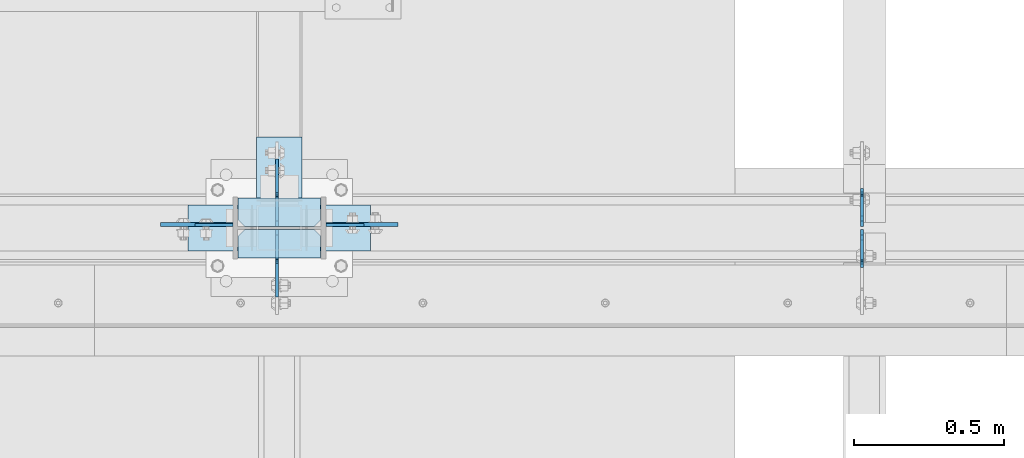
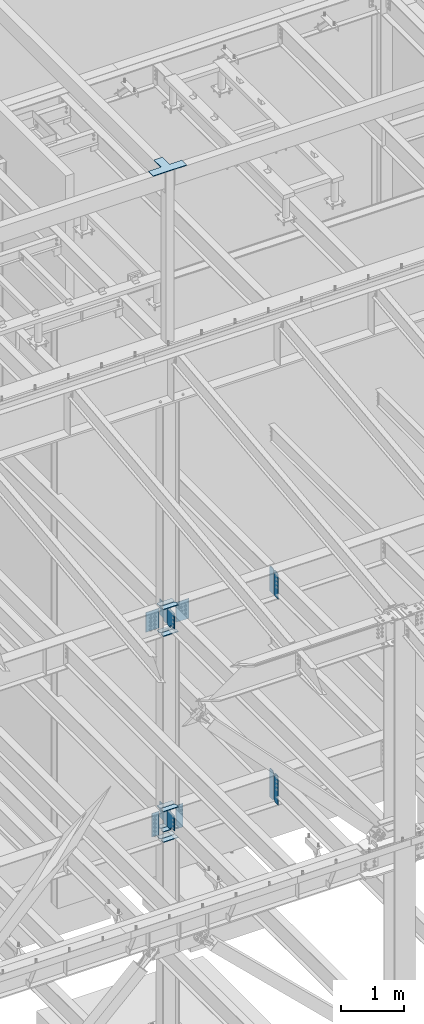
# One storey, part 1077 of 1179: 23 plates, 4 elements without a shape of their own.
"""IFC2X3 building model written with IfcOpenShell, lengths in millimetres."""

from ifc_helpers import new_model, si_unit, frame, origin_with_axes, place, context, subcontext, project, spatial, faceted_brep, material, type_object, element, aggregate, save


model = new_model("IFC2X3")

# Units and contexts
model_context = context("Model", 3, precision=1e-05, world=origin_with_axes())
body_context = subcontext(model_context, "Body", "Model", "MODEL_VIEW")
ifc_project = project(units=[si_unit("LENGTHUNIT", "METRE", prefix="MILLI"), si_unit("AREAUNIT", "SQUARE_METRE"), si_unit("VOLUMEUNIT", "CUBIC_METRE"), si_unit("MASSUNIT", "GRAM", prefix="KILO"), si_unit("TIMEUNIT", "SECOND"), si_unit("PLANEANGLEUNIT", "RADIAN"), si_unit("SOLIDANGLEUNIT", "STERADIAN"), si_unit("THERMODYNAMICTEMPERATUREUNIT", "DEGREE_CELSIUS"), si_unit("LUMINOUSINTENSITYUNIT", "LUMEN")], contexts=[model_context])

# Site, building, storey
site_placement = place(None, origin_with_axes())
site = spatial("IfcSite", under=ifc_project, at=site_placement, CompositionType="ELEMENT")
building_placement = place(site_placement, origin_with_axes())
building = spatial("IfcBuilding", under=site, at=building_placement, Name="Undefined", CompositionType="ELEMENT")
storey_placement = place(building_placement, origin_with_axes())
storey = spatial("IfcBuildingStorey", under=building, at=storey_placement, Name="Undefined", CompositionType="ELEMENT", Elevation=0.0)

# Assembly, plates
assembly_1_placement = place(storey_placement, origin_with_axes())
assembly_1 = element("IfcElementAssembly", 1, at=assembly_1_placement, inside=storey, Name="BEAM", AssemblyPlace="NOTDEFINED", PredefinedType="RIGID_FRAME")
ifc_material_1 = material(Name="STEEL/A36")
plate_type_1 = type_object("IfcPlateType", PredefinedType="NOTDEFINED")
plate_1_placement = place(assembly_1_placement, frame((18407.0620000839, 34396.3625, 7497.7625), z_axis=(0.0, 0.0, 1.0), x_axis=(0.0, 1.0, 0.0)))
plate_1 = element("IfcPlate", 2, at=plate_1_placement, type_object=plate_type_1, material=ifc_material_1, Name="PLATE", context=body_context, shape_type="Brep", body=[
    faceted_brep([(100.012500000004, -4.76250000000073, 498.475), (100.012500000004, -4.76250000000073, 493.712499809265), (100.012500000004, 4.76250000000073, 493.712499809265), (100.012500000004, 4.76250000000073, 498.475), (100.979229922596, -4.76250000000073, 488.852420291219), (100.979229922596, 4.76250000000073, 488.852420291219), (103.732243823069, -4.76250000000073, 484.732243823066), (103.732243823069, 4.76250000000073, 484.732243823066), (107.852420291223, -4.76250000000073, 481.979229922587), (107.852420291223, 4.76250000000073, 481.979229922587), (112.71249980927, -4.76250000000073, 481.0125), (112.71249980927, 4.76250000000073, 481.0125), (127.000007629395, -4.76250000000073, 481.0125), (127.0, 4.76250000000073, 481.0125), (0.0, -4.76250000000073, 479.425006866455), (19.0499992370605, -4.76250000000073, 498.475006103516), (19.0499992370605, 4.76250000000073, 498.475006103516), (0.0, 4.76250000000073, 479.425006866455), (0.0, -4.76250000000073, 19.0499992370605), (0.0, 4.76250000000073, 19.0499992370605), (19.0499992370605, -4.76250000000073, 0.0), (19.0499992370605, 4.76250000000073, 0.0), (127.0, -4.76250000000073, 0.0), (127.0, 4.76250000000073, 0.0)], [[[0, 1, 2, 3]], [[4, 5, 2, 1]], [[6, 7, 5, 4]], [[8, 9, 7, 6]], [[10, 11, 9, 8]], [[12, 13, 11, 10]], [[14, 15, 16, 17]], [[18, 14, 17, 19]], [[20, 18, 19, 21]], [[22, 20, 21, 23]], [[8, 6, 4, 1, 0, 15, 14, 18, 20, 22, 12, 10]], [[16, 15, 0, 3]], [[23, 21, 19, 17, 16, 3, 2, 5, 7, 9, 11, 13]], [[22, 23, 13, 12]]]),
])
plate_2_placement = place(assembly_1_placement, frame((18407.0620000839, 34386.8375, 7497.7625), z_axis=(0.0, 0.0, 1.0), x_axis=(0.0, -1.0, 0.0)))
plate_2 = element("IfcPlate", 3, at=plate_2_placement, type_object=plate_type_1, material=ifc_material_1, Name="PLATE", context=body_context, shape_type="Brep", body=[
    faceted_brep([(100.012500000004, -4.76250000000073, 498.475), (100.012500000004, -4.76250000000073, 493.712499809265), (100.012500000004, 4.76250000000073, 493.712499809265), (100.012500000004, 4.76250000000073, 498.475), (100.979229922596, -4.76250000000073, 488.852420291219), (100.979229922596, 4.76250000000073, 488.852420291219), (103.732243823069, -4.76250000000073, 484.732243823066), (103.732243823069, 4.76250000000073, 484.732243823066), (107.852420291223, -4.76250000000073, 481.979229922587), (107.852420291223, 4.76250000000073, 481.979229922587), (112.71249980927, -4.76250000000073, 481.0125), (112.71249980927, 4.76250000000073, 481.0125), (127.000007629395, -4.76250000000073, 481.0125), (127.0, 4.76250000000073, 481.0125), (0.0, -4.76250000000073, 479.425006866455), (19.0499992370605, -4.76250000000073, 498.475006103516), (19.0499992370605, 4.76250000000073, 498.475006103516), (0.0, 4.76250000000073, 479.425006866455), (0.0, -4.76250000000073, 19.0499992370605), (0.0, 4.76250000000073, 19.0499992370605), (19.0499992370605, -4.76250000000073, 0.0), (19.0499992370605, 4.76250000000073, 0.0), (127.0, -4.76250000000073, 0.0), (127.0, 4.76250000000073, 0.0)], [[[0, 1, 2, 3]], [[4, 5, 2, 1]], [[6, 7, 5, 4]], [[8, 9, 7, 6]], [[10, 11, 9, 8]], [[12, 13, 11, 10]], [[14, 15, 16, 17]], [[18, 14, 17, 19]], [[20, 18, 19, 21]], [[22, 20, 21, 23]], [[8, 6, 4, 1, 0, 15, 14, 18, 20, 22, 12, 10]], [[16, 15, 0, 3]], [[23, 21, 19, 17, 16, 3, 2, 5, 7, 9, 11, 13]], [[22, 23, 13, 12]]]),
])
aggregate(assembly_1, [plate_1, plate_2])

assembly_2_placement = place(storey_placement, origin_with_axes())
assembly_2 = element("IfcElementAssembly", 4, at=assembly_2_placement, inside=storey, Name="COLUMN", AssemblyPlace="NOTDEFINED", PredefinedType="RIGID_FRAME")
plate_3_placement = place(assembly_2_placement, frame((16614.775, 34401.91875, 4051.3), z_axis=(1.0, 0.0, 0.0), x_axis=(0.0, 0.0, -1.0)))
plate_3 = element("IfcPlate", 5, at=plate_3_placement, type_object=plate_type_1, material=ifc_material_1, Name="PLATE", context=body_context, shape_type="Brep", body=[
    faceted_brep([(0.0, -4.76249999999709, 0.0), (0.0, -4.76249999999709, 127.0), (0.0, 4.76249999999709, 127.0), (0.0, 4.76249999999709, 0.0), (457.200012207031, -4.76250000000073, 127.0), (457.200012207031, 4.76250000000073, 127.0), (457.200012207031, -4.76250000000073, 0.0), (457.200012207031, 4.76250000000073, 0.0)], [[[0, 1, 2, 3]], [[1, 4, 5, 2]], [[4, 6, 7, 5]], [[6, 0, 3, 7]], [[5, 7, 3, 2]], [[6, 4, 1, 0]]]),
])
plate_4_placement = place(assembly_2_placement, frame((16303.625, 34401.91875, 4051.3), z_axis=(-1.0, 0.0, 0.0), x_axis=(0.0, 0.0, -1.0)))
plate_4 = element("IfcPlate", 6, at=plate_4_placement, type_object=plate_type_1, material=ifc_material_1, Name="PLATE", context=body_context, shape_type="Brep", body=[
    faceted_brep([(0.0, -4.76249999999709, 0.0), (0.0, -4.76249999999709, 127.0), (0.0, 4.76249999999709, 127.0), (0.0, 4.76249999999709, 0.0), (457.200012207031, -4.76250000000073, 127.0), (457.200012207031, 4.76250000000073, 127.0), (457.200012207031, -4.76250000000073, 0.0), (457.200012207031, 4.76250000000073, 0.0)], [[[0, 1, 2, 3]], [[1, 4, 5, 2]], [[4, 6, 7, 5]], [[6, 0, 3, 7]], [[5, 7, 3, 2]], [[6, 4, 1, 0]]]),
])

assembly_3_placement = place(storey_placement, origin_with_axes())
assembly_3 = element("IfcElementAssembly", 7, at=assembly_3_placement, inside=storey, Name="BEAM", AssemblyPlace="NOTDEFINED", PredefinedType="RIGID_FRAME")
plate_5_placement = place(assembly_3_placement, frame((18407.0620000839, 34386.04375, 3514.725), z_axis=(0.0, 0.0, 1.0), x_axis=(0.0, -1.0, 0.0)))
plate_5 = element("IfcPlate", 8, at=plate_5_placement, type_object=plate_type_1, material=ifc_material_1, Name="PLATE", context=body_context, shape_type="Brep", body=[
    faceted_brep([(108.743750000001, -4.76250000000073, 571.5), (108.743750000001, -4.76250000000073, 568.324999809266), (108.743750000001, 4.76250000000073, 568.324999809266), (108.743750000001, 4.76250000000073, 571.5), (109.710479922593, -4.76250000000073, 563.46492029122), (109.710479922593, 4.76250000000073, 563.46492029122), (112.463493823067, -4.76250000000073, 559.344743823066), (112.463493823067, 4.76250000000073, 559.344743823066), (116.58367029122, -4.76250000000073, 556.591729922588), (116.58367029122, 4.76250000000073, 556.591729922588), (121.443749809267, -4.76250000000073, 555.625), (121.443749809267, 4.76250000000073, 555.625), (127.000004116075, -4.76250000000073, 555.625), (127.000004116075, 4.76250000000073, 555.625), (0.0, -4.76250000000073, 536.575000762939), (34.9249992370605, -4.76250000000073, 571.5), (34.9249992370605, 4.76250000000073, 571.5), (0.0, 4.76250000000073, 536.575000762939), (0.0, -4.76250000000073, 34.9249999999993), (0.0, 4.76250000000073, 34.9249999999993), (34.9249992370715, -4.76249999996799, 0.0), (34.9249992370678, 4.76250000003347, 0.0), (127.0, -4.76250000000073, 0.0), (127.0, 4.76250000000073, 0.0)], [[[0, 1, 2, 3]], [[4, 5, 2, 1]], [[6, 7, 5, 4]], [[8, 9, 7, 6]], [[10, 11, 9, 8]], [[12, 13, 11, 10]], [[14, 15, 16, 17]], [[18, 14, 17, 19]], [[20, 18, 19, 21]], [[22, 20, 21, 23]], [[8, 6, 4, 1, 0, 15, 14, 18, 20, 22, 12, 10]], [[16, 15, 0, 3]], [[23, 21, 19, 17, 16, 3, 2, 5, 7, 9, 11, 13]], [[22, 23, 13, 12]]]),
])
plate_6_placement = place(assembly_3_placement, frame((18407.0620000839, 34397.15625, 3514.725), z_axis=(0.0, 0.0, 1.0), x_axis=(0.0, 1.0, 0.0)))
plate_6 = element("IfcPlate", 9, at=plate_6_placement, type_object=plate_type_1, material=ifc_material_1, Name="PLATE", context=body_context, shape_type="Brep", body=[
    faceted_brep([(108.743750000001, -4.76250000000073, 571.5), (108.743750000001, -4.76250000000073, 568.324999809266), (108.743750000001, 4.76250000000073, 568.324999809266), (108.743750000001, 4.76250000000073, 571.5), (109.710479922593, -4.76250000000073, 563.46492029122), (109.710479922593, 4.76250000000073, 563.46492029122), (112.463493823067, -4.76250000000073, 559.344743823066), (112.463493823067, 4.76250000000073, 559.344743823066), (116.58367029122, -4.76250000000073, 556.591729922588), (116.58367029122, 4.76250000000073, 556.591729922588), (121.443749809267, -4.76250000000073, 555.625), (121.443749809267, 4.76250000000073, 555.625), (127.000004116075, -4.76250000000073, 555.625), (127.000004116075, 4.76250000000073, 555.625), (0.0, -4.76250000000073, 536.575000762939), (34.9249992370605, -4.76250000000073, 571.5), (34.9249992370605, 4.76250000000073, 571.5), (0.0, 4.76250000000073, 536.575000762939), (0.0, -4.76250000000073, 34.9249999999993), (0.0, 4.76250000000073, 34.9249999999993), (34.9249992370715, -4.76249999996799, 0.0), (34.9249992370678, 4.76250000003347, 0.0), (127.0, -4.76250000000073, 0.0), (127.0, 4.76250000000073, 0.0)], [[[0, 1, 2, 3]], [[4, 5, 2, 1]], [[6, 7, 5, 4]], [[8, 9, 7, 6]], [[10, 11, 9, 8]], [[12, 13, 11, 10]], [[14, 15, 16, 17]], [[18, 14, 17, 19]], [[20, 18, 19, 21]], [[22, 20, 21, 23]], [[8, 6, 4, 1, 0, 15, 14, 18, 20, 22, 12, 10]], [[16, 15, 0, 3]], [[23, 21, 19, 17, 16, 3, 2, 5, 7, 9, 11, 13]], [[22, 23, 13, 12]]]),
])
aggregate(assembly_3, [plate_5, plate_6])

# Plate
ifc_material_2 = material(Name="STEEL/A572-GR.50")
plate_type_2 = type_object("IfcPlateType", PredefinedType="NOTDEFINED")
plate_7_placement = place(assembly_2_placement, frame((16597.3125, 34491.6125, 8005.7625), z_axis=(-1.0, 0.0, 0.0), x_axis=(0.0, -1.0, 0.0)))
plate_7 = element("IfcPlate", 10, at=plate_7_placement, type_object=plate_type_2, material=ifc_material_2, Name="PLATE", context=body_context, shape_type="Brep", body=[
    faceted_brep([(0.0, -7.9375, 0.0), (0.0, -7.9375, 276.225006103516), (0.0, 7.9375, 276.225006103516), (0.0, 7.9375, 0.0), (73.0249996185303, -7.9375, 276.225006103516), (73.0249996185303, 7.9375, 276.225006103516), (95.25, -7.9375, 254.000005722046), (95.25, 7.9375, 254.000005722046), (95.25, -7.9375, 22.2250003814697), (95.25, 7.9375, 22.2250003814697), (73.0249996185303, -7.9375, 0.0), (73.0249996185303, 7.9375, 0.0)], [[[0, 1, 2, 3]], [[1, 4, 5, 2]], [[4, 6, 7, 5]], [[6, 8, 9, 7]], [[8, 10, 11, 9]], [[10, 0, 3, 11]], [[5, 7, 9, 11, 3, 2]], [[10, 8, 6, 4, 1, 0]]]),
])

plate_8_placement = place(assembly_2_placement, frame((16321.0875, 34291.5875, 8005.7625), z_axis=(1.0, 0.0, 0.0), x_axis=(0.0, 1.0, 0.0)))
plate_8 = element("IfcPlate", 11, at=plate_8_placement, type_object=plate_type_2, material=ifc_material_2, Name="PLATE", context=body_context, shape_type="Brep", body=[
    faceted_brep([(0.0, -7.9375, 0.0), (0.0, -7.9375, 276.225006103516), (0.0, 7.9375, 276.225006103516), (0.0, 7.9375, 0.0), (73.0249996185303, -7.9375, 276.225006103516), (73.0249996185303, 7.9375, 276.225006103516), (95.25, -7.9375, 254.000005722046), (95.25, 7.9375, 254.000005722046), (95.25, -7.9375, 22.2250003814697), (95.25, 7.9375, 22.2250003814697), (73.0249996185303, -7.9375, 0.0), (73.0249996185303, 7.9375, 0.0)], [[[0, 1, 2, 3]], [[1, 4, 5, 2]], [[4, 6, 7, 5]], [[6, 8, 9, 7]], [[8, 10, 11, 9]], [[10, 0, 3, 11]], [[5, 7, 9, 11, 3, 2]], [[10, 8, 6, 4, 1, 0]]]),
])

plate_9_placement = place(assembly_2_placement, frame((16597.3125, 34386.8375, 7488.2375), z_axis=(-1.0, 0.0, 0.0), x_axis=(0.0, -1.0, 0.0)))
plate_9 = element("IfcPlate", 12, at=plate_9_placement, type_object=plate_type_2, material=ifc_material_2, Name="PLATE", context=body_context, shape_type="Brep", body=[
    faceted_brep([(0.0, -7.9375, 22.2250003814697), (0.0, -7.9375, 254.000005722046), (0.0, 7.9375, 254.000005722046), (0.0, 7.9375, 22.2250003814697), (22.2250003814697, -7.9375, 276.225006103516), (22.2250003814697, 7.9375, 276.225006103516), (95.25, -7.9375, 276.225006103516), (95.25, 7.9375, 276.225006103516), (95.25, -7.9375, 0.0), (95.25, 7.9375, 0.0), (22.2250003814697, -7.9375, 0.0), (22.2250003814697, 7.9375, 0.0)], [[[0, 1, 2, 3]], [[1, 4, 5, 2]], [[4, 6, 7, 5]], [[6, 8, 9, 7]], [[8, 10, 11, 9]], [[10, 0, 3, 11]], [[5, 7, 9, 11, 3, 2]], [[10, 8, 6, 4, 1, 0]]]),
])

plate_10_placement = place(assembly_2_placement, frame((16597.3125, 34491.6125, 7488.2375), z_axis=(-1.0, 0.0, 0.0), x_axis=(0.0, -1.0, 0.0)))
plate_10 = element("IfcPlate", 13, at=plate_10_placement, type_object=plate_type_2, material=ifc_material_2, Name="PLATE", context=body_context, shape_type="Brep", body=[
    faceted_brep([(0.0, -7.9375, 0.0), (0.0, -7.9375, 276.225006103516), (0.0, 7.9375, 276.225006103516), (0.0, 7.9375, 0.0), (73.0249996185303, -7.9375, 276.225006103516), (73.0249996185303, 7.9375, 276.225006103516), (95.25, -7.9375, 254.000005722046), (95.25, 7.9375, 254.000005722046), (95.25, -7.9375, 22.2250003814697), (95.25, 7.9375, 22.2250003814697), (73.0249996185303, -7.9375, 0.0), (73.0249996185303, 7.9375, 0.0)], [[[0, 1, 2, 3]], [[1, 4, 5, 2]], [[4, 6, 7, 5]], [[6, 8, 9, 7]], [[8, 10, 11, 9]], [[10, 0, 3, 11]], [[5, 7, 9, 11, 3, 2]], [[10, 8, 6, 4, 1, 0]]]),
])

plate_type_3 = type_object("IfcPlateType", PredefinedType="NOTDEFINED")
plate_11_placement = place(assembly_2_placement, frame((16597.3125, 34386.8375, 3505.2), z_axis=(-1.0, 0.0, 0.0), x_axis=(0.0, -1.0, 0.0)))
plate_11 = element("IfcPlate", 14, at=plate_11_placement, type_object=plate_type_3, material=ifc_material_1, Name="PLATE", context=body_context, shape_type="Brep", body=[
    faceted_brep([(0.0, -6.34999999999854, 22.2250003814697), (0.0, -6.35000000000036, 254.000005722046), (0.0, 6.35000000000036, 254.000005722046), (0.0, 6.34999999999854, 22.2250003814697), (22.2250003814697, -6.35000000000036, 276.225006103516), (22.2250003814697, 6.35000000000036, 276.225006103516), (95.25, -6.35000000000036, 276.225006103516), (95.25, 6.35000000000036, 276.225006103516), (95.25, -6.34999999999309, 1.81898940354586e-12), (95.25, 6.34999999999854, -1.81898940354586e-12), (22.2250003814697, -6.34999999999854, 0.0), (22.2250003814697, 6.34999999999854, 0.0)], [[[0, 1, 2, 3]], [[1, 4, 5, 2]], [[4, 6, 7, 5]], [[6, 8, 9, 7]], [[8, 10, 11, 9]], [[10, 0, 3, 11]], [[5, 7, 9, 11, 3, 2]], [[10, 8, 6, 4, 1, 0]]]),
])

plate_12_placement = place(assembly_2_placement, frame((16597.3125, 34491.6125, 3505.2), z_axis=(-1.0, 0.0, 0.0), x_axis=(0.0, -1.0, 0.0)))
plate_12 = element("IfcPlate", 15, at=plate_12_placement, type_object=plate_type_3, material=ifc_material_1, Name="PLATE", context=body_context, shape_type="Brep", body=[
    faceted_brep([(0.0, -6.34999999999854, 0.0), (0.0, -6.35000000000036, 276.225006103516), (0.0, 6.35000000000036, 276.225006103516), (0.0, 6.34999999999854, 0.0), (73.0249996185303, -6.35000000000036, 276.225006103516), (73.0249996185303, 6.35000000000036, 276.225006103516), (95.25, -6.35000000000036, 254.000005722046), (95.25, 6.35000000000036, 254.000005722046), (95.25, -6.35000000000036, 22.2250003814697), (95.25, 6.35000000000036, 22.2250003814697), (73.0249999999996, -6.34999999999854, 0.0), (73.0249999999996, 6.34999999999854, 0.0)], [[[0, 1, 2, 3]], [[1, 4, 5, 2]], [[4, 6, 7, 5]], [[6, 8, 9, 7]], [[8, 10, 11, 9]], [[10, 0, 3, 11]], [[5, 7, 9, 11, 3, 2]], [[10, 8, 6, 4, 1, 0]]]),
])

plate_13_placement = place(assembly_2_placement, frame((16321.0875, 34291.5875, 3705.225), z_axis=(1.0, 0.0, 0.0), x_axis=(0.0, 1.0, 0.0)))
plate_13 = element("IfcPlate", 16, at=plate_13_placement, type_object=plate_type_3, material=ifc_material_1, Name="PLATE", context=body_context, shape_type="Brep", body=[
    faceted_brep([(0.0, -6.34999999999854, 0.0), (0.0, -6.35000000000036, 276.225006103516), (0.0, 6.35000000000036, 276.225006103516), (0.0, 6.34999999999854, 0.0), (73.0249996185303, -6.35000000000036, 276.225006103516), (73.0249996185303, 6.35000000000036, 276.225006103516), (95.25, -6.35000000000036, 254.000005722046), (95.25, 6.35000000000036, 254.000005722046), (95.25, -6.35000000000036, 22.2250003814697), (95.25, 6.35000000000036, 22.2250003814697), (73.0249999999996, -6.34999999999854, 0.0), (73.0249999999996, 6.34999999999854, 0.0)], [[[0, 1, 2, 3]], [[1, 4, 5, 2]], [[4, 6, 7, 5]], [[6, 8, 9, 7]], [[8, 10, 11, 9]], [[10, 0, 3, 11]], [[5, 7, 9, 11, 3, 2]], [[10, 8, 6, 4, 1, 0]]]),
])

plate_14_placement = place(assembly_2_placement, frame((16321.0875, 34291.5875, 4095.75), z_axis=(1.0, 0.0, 0.0), x_axis=(0.0, 1.0, 0.0)))
plate_14 = element("IfcPlate", 17, at=plate_14_placement, type_object=plate_type_3, material=ifc_material_1, Name="PLATE", context=body_context, shape_type="Brep", body=[
    faceted_brep([(0.0, -6.34999999999854, 0.0), (0.0, -6.35000000000036, 276.225006103516), (0.0, 6.35000000000036, 276.225006103516), (0.0, 6.34999999999854, 0.0), (73.0249996185303, -6.35000000000036, 276.225006103516), (73.0249996185303, 6.35000000000036, 276.225006103516), (95.25, -6.35000000000036, 254.000005722046), (95.25, 6.35000000000036, 254.000005722046), (95.25, -6.35000000000036, 22.2250003814697), (95.25, 6.35000000000036, 22.2250003814697), (73.0249999999996, -6.34999999999854, 0.0), (73.0249999999996, 6.34999999999854, 0.0)], [[[0, 1, 2, 3]], [[1, 4, 5, 2]], [[4, 6, 7, 5]], [[6, 8, 9, 7]], [[8, 10, 11, 9]], [[10, 0, 3, 11]], [[5, 7, 9, 11, 3, 2]], [[10, 8, 6, 4, 1, 0]]]),
])

plate_15_placement = place(assembly_2_placement, frame((16597.3125, 34491.6125, 3705.225), z_axis=(-1.0, 0.0, 0.0), x_axis=(0.0, -1.0, 0.0)))
plate_15 = element("IfcPlate", 18, at=plate_15_placement, type_object=plate_type_3, material=ifc_material_1, Name="PLATE", context=body_context, shape_type="Brep", body=[
    faceted_brep([(0.0, -6.34999999999854, 0.0), (0.0, -6.35000000000036, 276.225006103516), (0.0, 6.35000000000036, 276.225006103516), (0.0, 6.34999999999854, 0.0), (73.0249996185303, -6.35000000000036, 276.225006103516), (73.0249996185303, 6.35000000000036, 276.225006103516), (95.25, -6.35000000000036, 254.000005722046), (95.25, 6.35000000000036, 254.000005722046), (95.25, -6.35000000000036, 22.2250003814697), (95.25, 6.35000000000036, 22.2250003814697), (73.0249999999996, -6.34999999999854, 0.0), (73.0249999999996, 6.34999999999854, 0.0)], [[[0, 1, 2, 3]], [[1, 4, 5, 2]], [[4, 6, 7, 5]], [[6, 8, 9, 7]], [[8, 10, 11, 9]], [[10, 0, 3, 11]], [[5, 7, 9, 11, 3, 2]], [[10, 8, 6, 4, 1, 0]]]),
])

plate_16_placement = place(assembly_2_placement, frame((16597.3125, 34491.6125, 4095.75), z_axis=(-1.0, 0.0, 0.0), x_axis=(0.0, -1.0, 0.0)))
plate_16 = element("IfcPlate", 19, at=plate_16_placement, type_object=plate_type_3, material=ifc_material_1, Name="PLATE", context=body_context, shape_type="Brep", body=[
    faceted_brep([(0.0, -6.34999999999854, 0.0), (0.0, -6.35000000000036, 276.225006103516), (0.0, 6.35000000000036, 276.225006103516), (0.0, 6.34999999999854, 0.0), (73.0249996185303, -6.35000000000036, 276.225006103516), (73.0249996185303, 6.35000000000036, 276.225006103516), (95.25, -6.35000000000036, 254.000005722046), (95.25, 6.35000000000036, 254.000005722046), (95.25, -6.35000000000036, 22.2250003814697), (95.25, 6.35000000000036, 22.2250003814697), (73.0249999999996, -6.34999999999854, 0.0), (73.0249999999996, 6.34999999999854, 0.0)], [[[0, 1, 2, 3]], [[1, 4, 5, 2]], [[4, 6, 7, 5]], [[6, 8, 9, 7]], [[8, 10, 11, 9]], [[10, 0, 3, 11]], [[5, 7, 9, 11, 3, 2]], [[10, 8, 6, 4, 1, 0]]]),
])

# Assembly, plate
assembly_4_placement = place(storey_placement, origin_with_axes())
assembly_4 = element("IfcElementAssembly", 20, at=assembly_4_placement, inside=storey, Name="PLATE", AssemblyPlace="NOTDEFINED", PredefinedType="RIGID_FRAME")
plate_type_4 = type_object("IfcPlateType", PredefinedType="NOTDEFINED")
plate_17_placement = place(assembly_4_placement, frame((16764.0, 34467.8, 16433.8), z_axis=(0.0, -1.0, 0.0), x_axis=(-1.0, 0.0, 0.0)))
plate_17 = element("IfcPlate", 21, at=plate_17_placement, type_object=plate_type_4, material=ifc_material_1, Name="PLATE", context=body_context, shape_type="Brep", body=[
    faceted_brep([(0.0, -6.34999999999854, 0.0), (0.0, -6.34999999999854, 152.400000000001), (0.0, 6.34999999999854, 152.400000000001), (0.0, 6.34999999999854, 0.0), (609.600000000002, -6.34999999999854, 152.399999999994), (609.600000000002, 6.34999999999854, 152.399999999994), (609.600000000002, -6.34999999999854, 0.0), (609.600000000002, 6.34999999999854, 0.0), (381.000000000002, -6.34999999999854, 0.0), (381.000000000002, 6.34999999999854, 0.0), (381.000000000002, -6.34999999999854, -228.599999999999), (381.000000000002, 6.34999999999854, -228.599999999999), (228.600000000002, -6.34999999999854, -228.599999999999), (228.600000000002, 6.34999999999854, -228.599999999999), (228.600000000002, -6.34999999999854, 0.0), (228.600000000002, 6.34999999999854, 0.0)], [[[0, 1, 2, 3]], [[1, 4, 5, 2]], [[4, 6, 7, 5]], [[6, 8, 9, 7]], [[8, 10, 11, 9]], [[10, 12, 13, 11]], [[12, 14, 15, 13]], [[14, 0, 3, 15]], [[5, 7, 9, 11, 13, 15, 3, 2]], [[14, 12, 10, 8, 6, 4, 1, 0]]]),
])
aggregate(assembly_4, [plate_17])

# Plate
plate_type_5 = type_object("IfcPlateType", PredefinedType="NOTDEFINED")
plate_18_placement = place(assembly_2_placement, frame((16451.2620000839, 34396.3625, 7645.40000146665), z_axis=(0.0, 0.707106781186542, 0.707106781186553), x_axis=(0.0, 0.707106781186553, -0.707106781186542)))
plate_18 = element("IfcPlate", 22, at=plate_18_placement, type_object=plate_type_5, material=ifc_material_2, Name="PLATE", context=body_context, shape_type="Brep", body=[
    faceted_brep([(0.0, -4.76249999999709, 0.0), (-235.73172493462, -4.76250000000073, 235.731721421063), (-235.73172493462, 4.76250000000073, 235.731721421063), (0.0, 4.76249999999709, 0.0), (-235.731724934682, -4.76250000000073, 262.672489583438), (-235.731724934682, 4.76250000000073, 262.672489583438), (-179.605124832691, -4.76250000000073, 318.799089388474), (-179.605124832691, 4.76250000000073, 318.799089388474), (-172.394815745483, -4.76250000000073, 313.981314961322), (-172.394815745483, 4.76250000000073, 313.981314961322), (-163.889676302584, -4.76250000000073, 312.28953760572), (-163.889676302584, 4.76250000000073, 312.28953760572), (-155.3845368849, -4.76250000000073, 313.981315088055), (-155.3845368849, 4.76250000000073, 313.981315088055), (-148.174227869498, -4.76250000000073, 318.79908962264), (-148.174227869498, 4.76250000000073, 318.79908962264), (-74.0871122469689, -4.76250000000073, 392.886206349045), (-74.0871122469689, 4.76250000000073, 392.886206349045), (141.439036264685, -4.76250000000073, 177.360061049792), (141.439036264685, 4.76250000000073, 177.360061049792), (69.5969841162332, -4.76250000000073, 105.518007830909), (69.5969841162332, 4.76250000000073, 105.518007830909), (64.0909563766836, -4.76250000000073, 97.2776548535985), (64.0909563766836, 4.76250000000073, 97.2776548535985), (62.1574966039516, -4.76250000000073, 87.5574958031284), (62.1574966039516, 4.76250000000073, 87.5574958031284), (64.0909565215625, -4.76250000000073, 77.8373367814602), (64.0909565215625, 4.76250000000073, 77.8373367814602), (69.5969843839302, -4.76250000000073, 69.5969838861893), (69.5969843839302, 4.76250000000073, 69.5969838861893), (83.0673691195552, -4.76249999999709, 56.126600756339), (83.0673691195552, 4.76249999999709, 56.126600756339), (26.9407683631525, -4.76249999999709, -6.18456397205591e-11), (26.9407683631525, 4.76249999999709, -6.18456397205591e-11)], [[[0, 1, 2, 3]], [[1, 4, 5, 2]], [[4, 6, 7, 5]], [[6, 8, 9, 7]], [[8, 10, 11, 9]], [[10, 12, 13, 11]], [[12, 14, 15, 13]], [[14, 16, 17, 15]], [[16, 18, 19, 17]], [[18, 20, 21, 19]], [[20, 22, 23, 21]], [[22, 24, 25, 23]], [[24, 26, 27, 25]], [[26, 28, 29, 27]], [[28, 30, 31, 29]], [[30, 32, 33, 31]], [[32, 0, 3, 33]], [[5, 7, 9, 11, 13, 15, 17, 19, 21, 23, 25, 27, 29, 31, 33, 3, 2]], [[32, 30, 28, 26, 24, 22, 20, 18, 16, 14, 12, 10, 8, 6, 4, 1, 0]]]),
])

plate_19_placement = place(assembly_2_placement, frame((16451.2620000839, 34386.8375, 7645.40000146665), z_axis=(0.0, -0.707106781186506, 0.707106781186589), x_axis=(0.0, -0.70710678118659, -0.707106781186505)))
plate_19 = element("IfcPlate", 23, at=plate_19_placement, type_object=plate_type_5, material=ifc_material_2, Name="PLATE", context=body_context, shape_type="Brep", body=[
    faceted_brep([(0.0, -4.76249999999709, 0.0), (-235.73172493462, -4.76250000000073, 235.731721421063), (-235.73172493462, 4.76250000000073, 235.731721421063), (0.0, 4.76249999999709, 0.0), (-235.731724934682, -4.76250000000073, 262.672489583438), (-235.731724934682, 4.76250000000073, 262.672489583438), (-179.605124832691, -4.76250000000073, 318.799089388474), (-179.605124832691, 4.76250000000073, 318.799089388474), (-172.394815745483, -4.76250000000073, 313.981314961322), (-172.394815745483, 4.76250000000073, 313.981314961322), (-163.889676302584, -4.76250000000073, 312.28953760572), (-163.889676302584, 4.76250000000073, 312.28953760572), (-155.3845368849, -4.76250000000073, 313.981315088055), (-155.3845368849, 4.76250000000073, 313.981315088055), (-148.174227869498, -4.76250000000073, 318.79908962264), (-148.174227869498, 4.76250000000073, 318.79908962264), (-74.0871122469689, -4.76250000000073, 392.886206349045), (-74.0871122469689, 4.76250000000073, 392.886206349045), (141.439036264685, -4.76250000000073, 177.360061049792), (141.439036264685, 4.76250000000073, 177.360061049792), (69.5969841162332, -4.76250000000073, 105.518007830909), (69.5969841162332, 4.76250000000073, 105.518007830909), (64.0909563766836, -4.76250000000073, 97.2776548535985), (64.0909563766836, 4.76250000000073, 97.2776548535985), (62.1574966039516, -4.76250000000073, 87.5574958031284), (62.1574966039516, 4.76250000000073, 87.5574958031284), (64.0909565215625, -4.76250000000073, 77.8373367814602), (64.0909565215625, 4.76250000000073, 77.8373367814602), (69.5969843839302, -4.76250000000073, 69.5969838861893), (69.5969843839302, 4.76250000000073, 69.5969838861893), (83.0673691195552, -4.76249999999709, 56.126600756339), (83.0673691195552, 4.76249999999709, 56.126600756339), (26.9407683631525, -4.76249999999709, -6.18456397205591e-11), (26.9407683631525, 4.76249999999709, -6.18456397205591e-11)], [[[0, 1, 2, 3]], [[1, 4, 5, 2]], [[4, 6, 7, 5]], [[6, 8, 9, 7]], [[8, 10, 11, 9]], [[10, 12, 13, 11]], [[12, 14, 15, 13]], [[14, 16, 17, 15]], [[16, 18, 19, 17]], [[18, 20, 21, 19]], [[20, 22, 23, 21]], [[22, 24, 25, 23]], [[24, 26, 27, 25]], [[26, 28, 29, 27]], [[28, 30, 31, 29]], [[30, 32, 33, 31]], [[32, 0, 3, 33]], [[5, 7, 9, 11, 13, 15, 17, 19, 21, 23, 25, 27, 29, 31, 33, 3, 2]], [[32, 30, 28, 26, 24, 22, 20, 18, 16, 14, 12, 10, 8, 6, 4, 1, 0]]]),
])

plate_20_placement = place(assembly_2_placement, frame((16451.2620000839, 34386.8375, 3730.62500146665), z_axis=(0.0, -0.707106781186506, 0.707106781186589), x_axis=(0.0, -0.70710678118659, -0.707106781186505)))
plate_20 = element("IfcPlate", 24, at=plate_20_placement, type_object=plate_type_5, material=ifc_material_1, Name="PLATE", context=body_context, shape_type="Brep", body=[
    faceted_brep([(0.0, -4.76249999999709, 0.0), (-240.221851238686, -4.76249999999709, 240.221851238675), (-240.221851238686, 4.76249999999709, 240.221851238675), (0.0, 4.76249999999709, 0.0), (-240.221851238757, -4.76249999999709, 267.162619601822), (-240.221851238757, 4.76249999999709, 267.162619601822), (-184.095246317615, -4.76250000000073, 323.289216042809), (-184.095246317615, 4.76250000000073, 323.289216042809), (-175.854893630505, -4.76250000000073, 317.783188345089), (-175.854893630505, 4.76250000000073, 317.783188345089), (-166.134734884679, -4.76250000000073, 315.84972839669), (-166.134734884679, 4.76250000000073, 315.84972839669), (-156.414576056737, -4.76250000000073, 317.783187932182), (-156.414576056737, 4.76250000000073, 317.783187932182), (-148.17422313576, -4.76250000000073, 323.289215279867), (-148.17422313576, 4.76250000000073, 323.289215279867), (-76.3321762094201, -4.76250000000073, 395.131256102708), (-76.3321762094201, 4.76250000000073, 395.131256102708), (139.193969726119, -4.76250000000073, 179.605117797448), (139.193969726119, 4.76250000000073, 179.605117797448), (67.3519197480127, -4.76250000000073, 107.763070871089), (67.3519197480127, 4.76250000000073, 107.763070871089), (61.8458917204443, -4.76250000000073, 99.5227179271387), (61.8458917204443, 4.76250000000073, 99.5227179271387), (59.9124317204551, -4.76250000000073, 89.8025587869961), (59.9124317204551, 4.76250000000073, 89.8025587869961), (61.8458915140363, -4.76250000000073, 80.0823996057879), (61.8458915140363, 4.76250000000073, 80.0823996057879), (67.3519193666289, -4.76250000000073, 71.8420465448944), (67.3519193666289, 4.76250000000073, 71.8420465448944), (83.0673691195552, -4.76249999999709, 56.126600756339), (83.0673691195552, 4.76249999999709, 56.126600756339), (26.9407683631525, -4.76249999999709, -6.18456397205591e-11), (26.9407683631525, 4.76249999999709, -6.18456397205591e-11)], [[[0, 1, 2, 3]], [[1, 4, 5, 2]], [[4, 6, 7, 5]], [[6, 8, 9, 7]], [[8, 10, 11, 9]], [[10, 12, 13, 11]], [[12, 14, 15, 13]], [[14, 16, 17, 15]], [[16, 18, 19, 17]], [[18, 20, 21, 19]], [[20, 22, 23, 21]], [[22, 24, 25, 23]], [[24, 26, 27, 25]], [[26, 28, 29, 27]], [[28, 30, 31, 29]], [[30, 32, 33, 31]], [[32, 0, 3, 33]], [[5, 7, 9, 11, 13, 15, 17, 19, 21, 23, 25, 27, 29, 31, 33, 3, 2]], [[32, 30, 28, 26, 24, 22, 20, 18, 16, 14, 12, 10, 8, 6, 4, 1, 0]]]),
])

plate_21_placement = place(assembly_2_placement, frame((16451.2620000839, 34396.3625, 3730.62500146665), z_axis=(0.0, 0.707106781186542, 0.707106781186553), x_axis=(0.0, 0.707106781186553, -0.707106781186542)))
plate_21 = element("IfcPlate", 25, at=plate_21_placement, type_object=plate_type_5, material=ifc_material_1, Name="PLATE", context=body_context, shape_type="Brep", body=[
    faceted_brep([(0.0, -4.76249999999709, 0.0), (-240.221851238686, -4.76249999999709, 240.221851238675), (-240.221851238686, 4.76249999999709, 240.221851238675), (0.0, 4.76249999999709, 0.0), (-240.221851238757, -4.76249999999709, 267.162619601822), (-240.221851238757, 4.76249999999709, 267.162619601822), (-184.095246317615, -4.76250000000073, 323.289216042809), (-184.095246317615, 4.76250000000073, 323.289216042809), (-175.854893630505, -4.76250000000073, 317.783188345089), (-175.854893630505, 4.76250000000073, 317.783188345089), (-166.134734884679, -4.76250000000073, 315.84972839669), (-166.134734884679, 4.76250000000073, 315.84972839669), (-156.414576056737, -4.76250000000073, 317.783187932182), (-156.414576056737, 4.76250000000073, 317.783187932182), (-148.17422313576, -4.76250000000073, 323.289215279867), (-148.17422313576, 4.76250000000073, 323.289215279867), (-76.3321762094201, -4.76250000000073, 395.131256102708), (-76.3321762094201, 4.76250000000073, 395.131256102708), (139.193969726119, -4.76250000000073, 179.605117797448), (139.193969726119, 4.76250000000073, 179.605117797448), (67.3519197480127, -4.76250000000073, 107.763070871089), (67.3519197480127, 4.76250000000073, 107.763070871089), (61.8458917204443, -4.76250000000073, 99.5227179271387), (61.8458917204443, 4.76250000000073, 99.5227179271387), (59.9124317204551, -4.76250000000073, 89.8025587869961), (59.9124317204551, 4.76250000000073, 89.8025587869961), (61.8458915140363, -4.76250000000073, 80.0823996057879), (61.8458915140363, 4.76250000000073, 80.0823996057879), (67.3519193666289, -4.76250000000073, 71.8420465448944), (67.3519193666289, 4.76250000000073, 71.8420465448944), (83.0673691195552, -4.76249999999709, 56.126600756339), (83.0673691195552, 4.76249999999709, 56.126600756339), (26.9407683631525, -4.76249999999709, -6.18456397205591e-11), (26.9407683631525, 4.76249999999709, -6.18456397205591e-11)], [[[0, 1, 2, 3]], [[1, 4, 5, 2]], [[4, 6, 7, 5]], [[6, 8, 9, 7]], [[8, 10, 11, 9]], [[10, 12, 13, 11]], [[12, 14, 15, 13]], [[14, 16, 17, 15]], [[16, 18, 19, 17]], [[18, 20, 21, 19]], [[20, 22, 23, 21]], [[22, 24, 25, 23]], [[24, 26, 27, 25]], [[26, 28, 29, 27]], [[28, 30, 31, 29]], [[30, 32, 33, 31]], [[32, 0, 3, 33]], [[5, 7, 9, 11, 13, 15, 17, 19, 21, 23, 25, 27, 29, 31, 33, 3, 2]], [[32, 30, 28, 26, 24, 22, 20, 18, 16, 14, 12, 10, 8, 6, 4, 1, 0]]]),
])

plate_type_6 = type_object("IfcPlateType", PredefinedType="NOTDEFINED")
plate_22_placement = place(assembly_2_placement, frame((16303.625, 34402.7125, 7975.6), z_axis=(-1.0, 0.0, 0.0), x_axis=(0.0, 0.0, -1.0)))
plate_22 = element("IfcPlate", 26, at=plate_22_placement, type_object=plate_type_6, material=ifc_material_2, Name="PLATE", context=body_context, shape_type="Brep", body=[
    faceted_brep([(0.0, -6.34999999999854, 0.0), (0.0, -6.34999999999854, 241.300003051758), (0.0, 6.34999999999854, 241.300003051758), (0.0, 6.34999999999854, 0.0), (381.0, -6.34999999999854, 241.300003051758), (381.0, 6.34999999999854, 241.300003051758), (381.000000000002, -6.34999999999854, 0.0), (381.000000000002, 6.34999999999854, 0.0)], [[[0, 1, 2, 3]], [[1, 4, 5, 2]], [[4, 6, 7, 5]], [[6, 0, 3, 7]], [[5, 7, 3, 2]], [[6, 4, 1, 0]]]),
])

plate_23_placement = place(assembly_2_placement, frame((16614.775, 34402.7125, 7975.6), z_axis=(1.0, 0.0, 0.0), x_axis=(0.0, 0.0, -1.0)))
plate_23 = element("IfcPlate", 27, at=plate_23_placement, type_object=plate_type_6, material=ifc_material_2, Name="PLATE", context=body_context, shape_type="Brep", body=[
    faceted_brep([(0.0, -6.34999999999854, 0.0), (0.0, -6.34999999999854, 241.300003051758), (0.0, 6.34999999999854, 241.300003051758), (0.0, 6.34999999999854, 0.0), (381.0, -6.34999999999854, 241.300003051758), (381.0, 6.34999999999854, 241.300003051758), (381.000000000002, -6.34999999999854, 0.0), (381.000000000002, 6.34999999999854, 0.0)], [[[0, 1, 2, 3]], [[1, 4, 5, 2]], [[4, 6, 7, 5]], [[6, 0, 3, 7]], [[5, 7, 3, 2]], [[6, 4, 1, 0]]]),
])

aggregate(assembly_2, [plate_7, plate_8, plate_9, plate_22, plate_10, plate_23, plate_18, plate_19, plate_11, plate_12, plate_3, plate_4, plate_13, plate_14, plate_20, plate_15, plate_16, plate_21])

save(model, "model.ifc")
